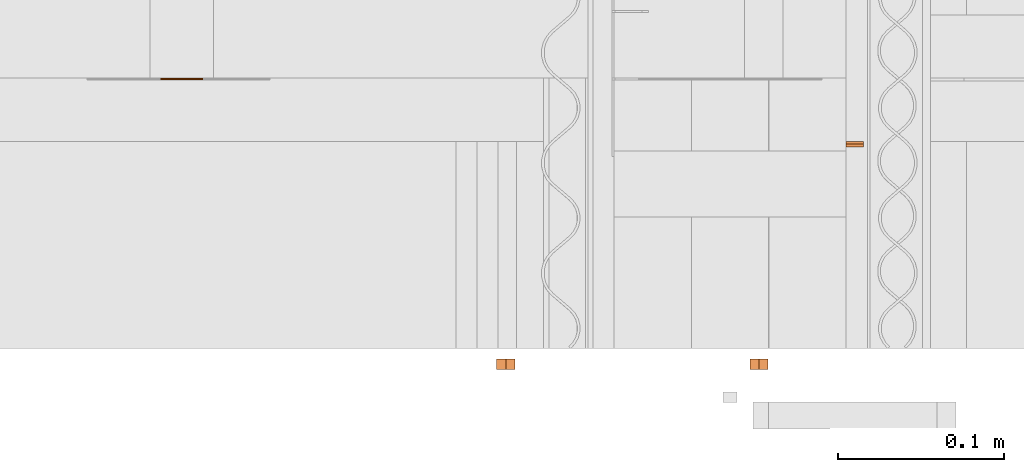
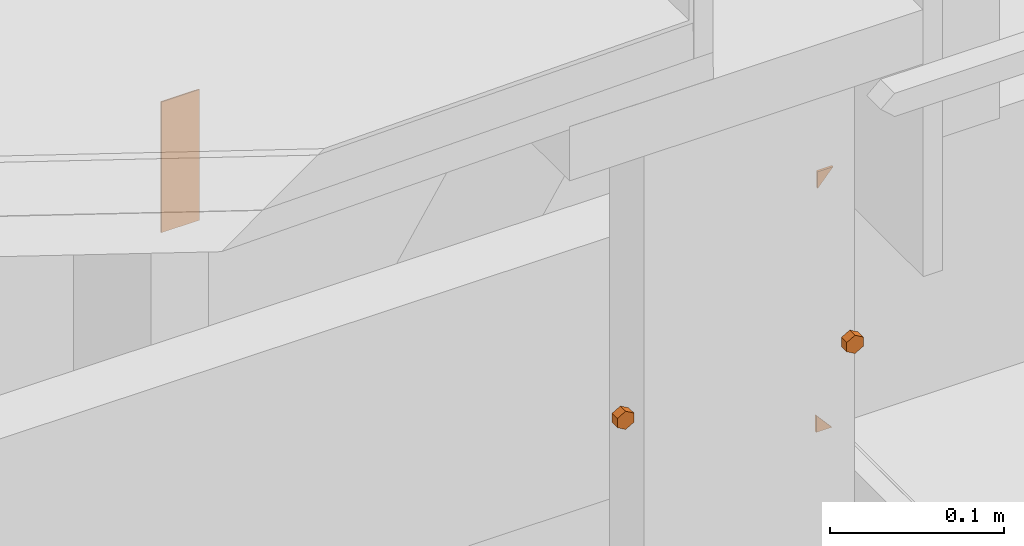
# One storey, part 17 of 22: 5 proxies.
"""IFC2X3 building model written with IfcOpenShell, lengths in feet."""

from ifc_helpers import new_model, entity, si_unit, converted_unit, frame, frame_2d, origin_with_axes, place, context, subcontext, project, spatial, polyline, rectangle, outline, extrude, source, transform, mapped, type_object, type_shapes, element, save


model = new_model("IFC2X3")

# Units and contexts
model_context = context("Model", 3, precision=1e-05)
plan_context = context("Plan", 2, precision=1e-05, world=frame_2d((0.0, 0.0, 0.0), x_axis=(1.0, 0.0, 0.0)))
body_context = subcontext(model_context, "Body", "Model", "MODEL_VIEW")
ifc_project = project(units=[converted_unit("VOLUMEUNIT", "cubic foot", entity("IfcReal", 0.0283168467116885), si_unit("VOLUMEUNIT", "CUBIC_METRE"), dimensions=[3, 0, 0, 0, 0, 0, 0]), converted_unit("AREAUNIT", "square foot", entity("IfcReal", 0.09290304), si_unit("AREAUNIT", "SQUARE_METRE"), dimensions=[2, 0, 0, 0, 0, 0, 0]), converted_unit("LENGTHUNIT", "foot", entity("IfcReal", 0.3048), si_unit("LENGTHUNIT", "METRE"), dimensions=[1, 0, 0, 0, 0, 0, 0])], contexts=[model_context, plan_context])

# Site, building, storey
site_placement = place(None, origin_with_axes())
site = spatial("IfcSite", under=ifc_project, at=site_placement, CompositionType="ELEMENT")
building_placement = place(site_placement, origin_with_axes())
building = spatial("IfcBuilding", under=site, at=building_placement, Name="Building", CompositionType="ELEMENT")
storey_placement = place(building_placement, origin_with_axes())
storey = spatial("IfcBuildingStorey", under=building, at=storey_placement, Name="Storey", CompositionType="ELEMENT")

# Proxies
building_element_proxy_type = type_object("IfcBuildingElementProxyType", PredefinedType="NOTDEFINED")
shared_shape = source(origin_with_axes(), body_context, "Body", "SweptSolid", [
    extrude(outline(polyline([(0.0210492300319429, -8.50838701768324e-10), (0.0105246142520914, 0.0182291696928539), (-0.0105246150159715, 0.0182291696928539), (-0.0210492300319429, -8.69586486698244e-11), (-0.0105246142520914, -0.0182291712206141), (0.0105246142520914, -0.0182291696928539), (0.0210492300319429, -8.50838701768324e-10)])), frame((1.73917297339649e-10, 0.0, 0.0), z_axis=(0.0, 0.0, -1.0), x_axis=(0.866025447845459, 0.5, 0.0)), (0.0, 0.0, -0.999999940395355), 0.0199999997321788),
])
type_shapes(building_element_proxy_type, [shared_shape])
for number, where, z_axis, x_axis in (
    (1, (1615.29551027954, 1.87001555297631, -60.3385860212832), (0.0, -1.0, -1.62920684942947e-07), (1.0, 0.0, 0.0)),
    (2, (1615.79552597887, 1.87001555297631, -60.3385860212832), (0.0, -1.0, -1.62920684942947e-07), (1.0, 0.0, 0.0)),
):
    element("IfcBuildingElementProxy", number, at=place(storey_placement, frame(where, z_axis=z_axis, x_axis=x_axis)), inside=storey, type_object=building_element_proxy_type, context=body_context, shape_type="MappedRepresentation", body=[
        mapped(shared_shape, transform((0.0, 0.0, 0.0), x_axis=(1.0, 0.0, 0.0), y_axis=(0.0, 1.0, 0.0), z_axis=(0.0, 0.0, 1.0), scale=1.0)),
    ])
proxy_placement = place(storey_placement, frame((1612.11859835727, 2.42211120178693, -60.0146371235685), z_axis=(0.0, 0.0, 1.0), x_axis=(1.0, 0.0, 0.0)))
element("IfcBuildingElementProxy", 3, at=proxy_placement, inside=storey, Name="Generic Models 852:Generic Models 1", context=body_context, shape_type="SweptSolid", body=[
    extrude(rectangle(XDim=0.0832806743717406, YDim=0.00277022707595213, at=frame_2d((0.0, 0.0, 0.0))), frame((2.53661352349079, 0.00138511354766121, 0.0), z_axis=(0.0, 0.0, -1.0), x_axis=(-1.0, 0.0, 0.0)), (0.0, 0.0, -1.0), 0.301264184929359),
])
for number, where, z_axis, x_axis, name in (
    (4, (1616.00938932163, 2.29467283396583, -60.8298722214586), (0.0, 1.0, -1.62920684942947e-07), (1.0, 0.0, 0.0), "Plane.031"),
    (5, (1616.00938932163, 2.29467283396583, -60.3091998363104), (0.0, -1.0, 1.94707183709397e-07), (1.0, 0.0, 0.0), "Plane.031"),
):
    element("IfcBuildingElementProxy", number, at=place(storey_placement, frame(where, z_axis=z_axis, x_axis=x_axis)), inside=storey, Name=name, context=body_context, shape_type="SweptSolid", body=[
        extrude(outline(polyline([(-0.0113787857040743, -0.0129610204120751), (0.0226940349199054, -0.0129610204120751), (-0.0113152530352314, 0.0259220438796704), (-0.0113787857040743, -0.0129610204120751)])), frame((-0.0302879514998886, 0.02870574199993, 0.00520832983292933), z_axis=(2.24190415565317e-07, 1.47708149711434e-07, -1.0), x_axis=(0.999999940395355, 1.79352340978767e-07, 2.24190429776172e-07)), (-1.84819015203175e-07, 1.30334129266885e-07, 1.0), 0.00520833323870617),
    ])

save(model, "model.ifc")
